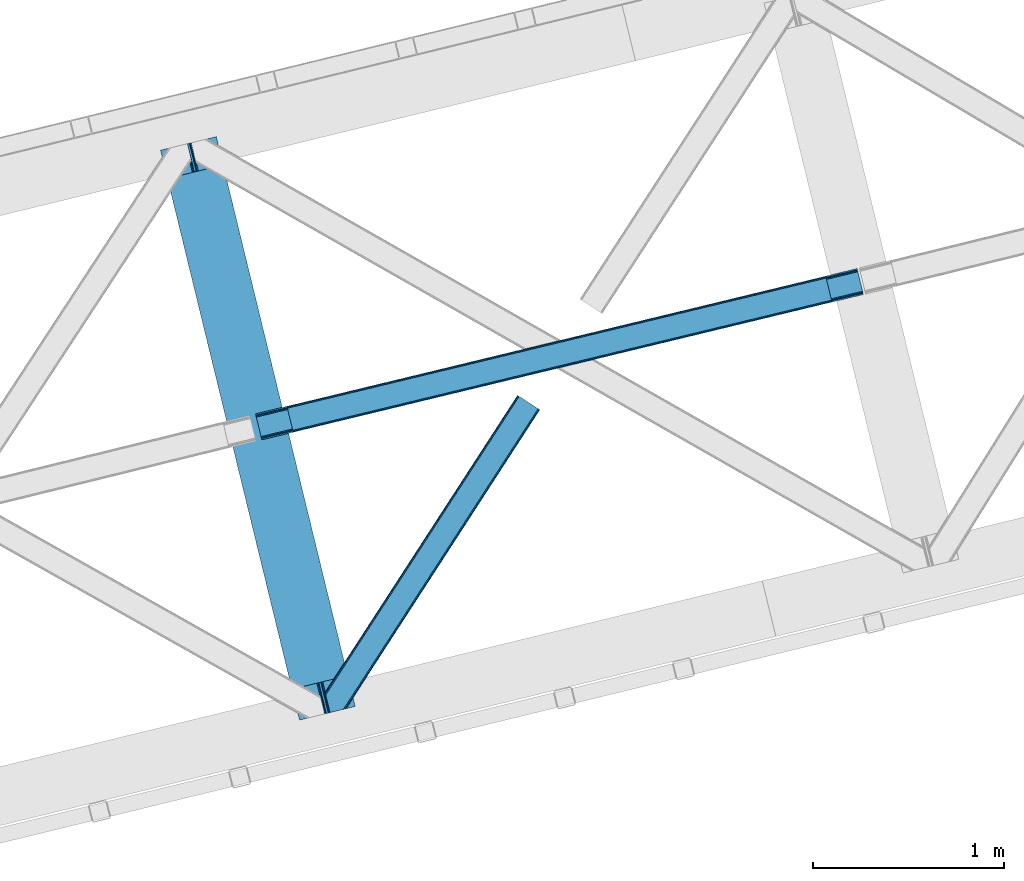
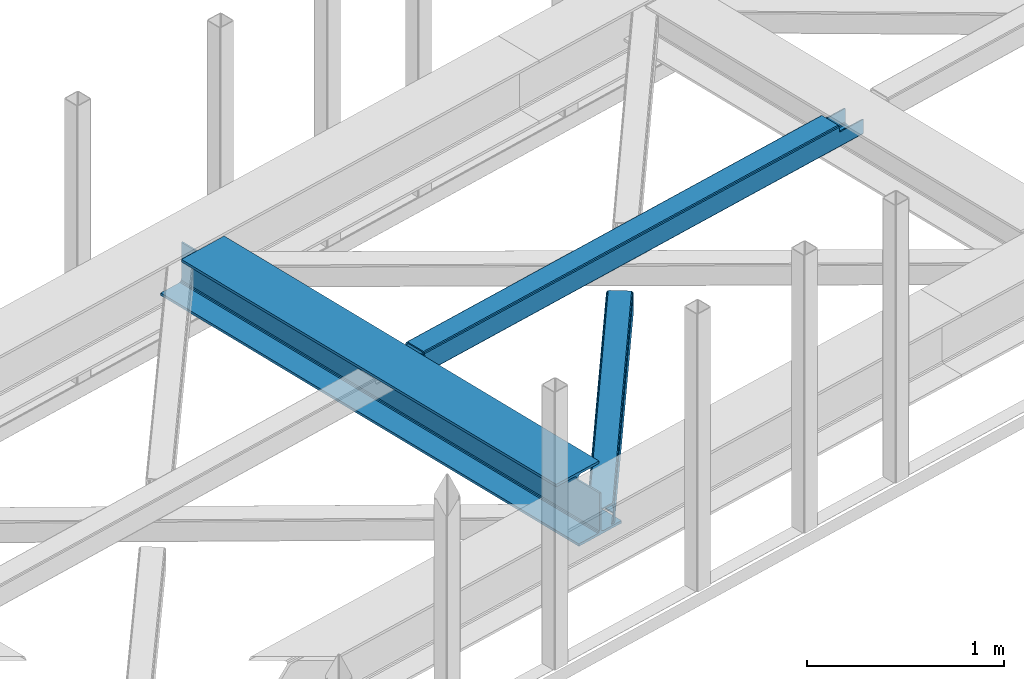
# One storey, part 36 of 67: 2 beams, 1 member.
"""IFC4 building model written with IfcOpenShell, lengths in millimetres."""

from ifc_helpers import new_model, entity, si_unit, converted_unit, derived_unit, direction, frame, origin, place, context, subcontext, project, spatial, triangles, polygons, material, type_object, element, save


model = new_model("IFC4")

# Units and contexts
model_context = context("Model", 3, precision=0.01, world=origin(), true_north=direction((6.12303176911189e-17, 1.0)))
plan_context = context("Plan", 3, precision=0.01, world=origin(), true_north=direction((6.12303176911189e-17, 1.0)))
body_context = subcontext(model_context, "Body", "Model", "MODEL_VIEW")
ifc_project = project(units=[si_unit("LENGTHUNIT", "METRE", prefix="MILLI"), si_unit("AREAUNIT", "SQUARE_METRE"), si_unit("VOLUMEUNIT", "CUBIC_METRE"), converted_unit("PLANEANGLEUNIT", "DEGREE", entity("IfcRatioMeasure", 0.0174532925199433), si_unit("PLANEANGLEUNIT", "RADIAN"), dimensions=[0, 0, 0, 0, 0, 0, 0]), si_unit("MASSUNIT", "GRAM", prefix="KILO"), derived_unit("MASSDENSITYUNIT", [(si_unit("MASSUNIT", "GRAM", prefix="KILO"), 1), (si_unit("LENGTHUNIT", "METRE"), -3)]), derived_unit("MOMENTOFINERTIAUNIT", [(si_unit("LENGTHUNIT", "METRE"), 4)]), si_unit("TIMEUNIT", "SECOND"), si_unit("FREQUENCYUNIT", "HERTZ"), si_unit("THERMODYNAMICTEMPERATUREUNIT", "DEGREE_CELSIUS"), derived_unit("THERMALTRANSMITTANCEUNIT", [(si_unit("MASSUNIT", "GRAM", prefix="KILO"), 1), (si_unit("THERMODYNAMICTEMPERATUREUNIT", "KELVIN"), -1), (si_unit("TIMEUNIT", "SECOND"), -3)]), derived_unit("VOLUMETRICFLOWRATEUNIT", [(si_unit("LENGTHUNIT", "METRE"), 3), (si_unit("TIMEUNIT", "SECOND"), -1)]), derived_unit("MASSFLOWRATEUNIT", [(si_unit("MASSUNIT", "GRAM", prefix="KILO"), 1), (si_unit("TIMEUNIT", "SECOND"), -1)]), derived_unit("ROTATIONALFREQUENCYUNIT", [(si_unit("TIMEUNIT", "SECOND"), -1)]), si_unit("ELECTRICCURRENTUNIT", "AMPERE"), si_unit("ELECTRICVOLTAGEUNIT", "VOLT"), si_unit("POWERUNIT", "WATT"), si_unit("FORCEUNIT", "NEWTON", prefix="KILO"), si_unit("ILLUMINANCEUNIT", "LUX"), si_unit("LUMINOUSFLUXUNIT", "LUMEN"), si_unit("LUMINOUSINTENSITYUNIT", "CANDELA"), derived_unit("USERDEFINED", [(si_unit("MASSUNIT", "GRAM", prefix="KILO"), -1), (si_unit("LENGTHUNIT", "METRE"), -2), (si_unit("TIMEUNIT", "SECOND"), 3), (si_unit("LUMINOUSFLUXUNIT", "LUMEN"), 1)]), derived_unit("LINEARVELOCITYUNIT", [(si_unit("LENGTHUNIT", "METRE"), 1), (si_unit("TIMEUNIT", "SECOND"), -1)]), si_unit("PRESSUREUNIT", "PASCAL"), derived_unit("USERDEFINED", [(si_unit("LENGTHUNIT", "METRE"), -2), (si_unit("MASSUNIT", "GRAM", prefix="KILO"), 1), (si_unit("TIMEUNIT", "SECOND"), -2)]), derived_unit("LINEARFORCEUNIT", [(si_unit("MASSUNIT", "GRAM", prefix="KILO"), 1), (si_unit("LENGTHUNIT", "METRE"), 1), (si_unit("TIMEUNIT", "SECOND"), -2), (si_unit("LENGTHUNIT", "METRE"), -1)]), derived_unit("PLANARFORCEUNIT", [(si_unit("MASSUNIT", "GRAM", prefix="KILO"), 1), (si_unit("LENGTHUNIT", "METRE"), 1), (si_unit("TIMEUNIT", "SECOND"), -2), (si_unit("LENGTHUNIT", "METRE"), -2)])], contexts=[model_context, plan_context])

# Site, building, storey
site_placement = place(None, origin())
site = spatial("IfcSite", under=ifc_project, at=site_placement, CompositionType="ELEMENT")
building_placement = place(site_placement, origin())
building = spatial("IfcBuilding", under=site, at=building_placement, CompositionType="ELEMENT")
storey_placement = place(building_placement, frame((0.0, 0.0, 19800.0)))
storey = spatial("IfcBuildingStorey", under=building, at=storey_placement, CompositionType="ELEMENT", Elevation=19800.0)

# Beams
ifc_material = material(Name="Metal painted (White)")
beam_type = type_object("IfcBeamType", PredefinedType="BEAM")
beam_1_placement = place(storey_placement, frame((-33462.5738387728, 9638.07281239183, 3807.02022389142)))
element("IfcBeam", 1, at=beam_1_placement, inside=storey, type_object=beam_type, material=ifc_material, ObjectType="Steel Beam", PredefinedType="BEAM", context=body_context, shape_type="Tessellation", body=[
    polygons([(1018.16648378329, 71.0478278971032, 15.5000000000008), (1018.16648378329, 71.0478278971032, 0.0), (291.465617442446, 3052.25531830422, 0.0), (291.465617442446, 3052.25531830421, 15.5000000000008), (894.779372399325, 40.970914087328, 15.5000000000008), (168.078506058474, 3022.17840449444, 15.5000000000008), (888.087028625375, 39.3395844888254, 16.8701684147984), (161.386162284524, 3020.54707489594, 16.8701684147984), (882.413533524755, 37.956610033653, 20.7720779386434), (155.7126671839, 3019.16410044076, 20.7720779386434), (878.62262529618, 37.0325360459173, 26.6116982174294), (151.921758955325, 3018.24002645303, 26.6116982174294), (877.291435352783, 36.708044413504, 33.500000000001), (150.590569011937, 3017.91553482062, 33.500000000001), (140.875048430518, 3015.54727389071, 33.500000000001), (140.875048430514, 3015.54727389071, 259.000000000002), (150.590569011932, 3017.91553482062, 259.000000000002), (-4.33146851719357e-12, 2981.20749040711, 0.0), (4.33146851719357e-12, 2981.20749040711, 15.4999999999965), (123.387111383968, 3011.28440421689, 15.5000000000008), (130.079455157926, 3012.91573381539, 16.8701684147984), (135.752950258542, 3014.29870827056, 20.7720779386391), (139.543858487122, 3015.2227822583, 26.6116982174294), (877.291435352779, 36.7080444135062, 259.000000000002), (867.575914771365, 34.3397834836025, 259.000000000002), (867.575914771365, 34.3397834836003, 33.500000000001), (866.244724827968, 34.0152918511859, 26.6116982174294), (862.453816599389, 33.0912178634513, 20.7720779386391), (856.780321498773, 31.7082434082789, 16.8701684147984), (850.087977724815, 30.0769138097752, 15.5000000000008), (726.700866340851, 2.16573425859679e-12, 15.4999999999965), (726.700866340851, 2.16573425859679e-12, 0.0), (838.124523615916, 197.385937999181, 259.069791973884), (186.469722099967, 2870.72539801218, 259.000000000002), (186.69311520182, 2869.80895360721, 259.617303331124), (186.705504045446, 2869.75812937344, 266.500003008253), (837.979344808143, 197.981416001706, 266.500002998871), (837.979694928895, 197.979979696973, 260.000004007589), (828.499586345872, 194.645865944432, 259.006343171919), (828.276216326111, 195.562317481914, 259.617303331124), (828.263827482481, 195.613141715685, 266.500003008253), (176.989986719788, 2867.38985508742, 266.500002998871), (176.989636599032, 2867.39129139215, 260.000004007589), (176.844830940692, 2867.98534020594, 259.07612046749), (176.754201518548, 2868.35713708228, 259.000000000002), (839.31083267807, 198.304685446393, 273.388305639783), (843.101109266766, 199.231350618306, 279.227924098781), (848.774180214305, 200.616065081981, 283.129832400619), (855.466371895425, 202.248018612794, 284.500000377228), (978.853400583278, 232.325271667905, 284.500000138971), (978.851730776613, 232.332121736637, 299.999995328161), (687.386308679347, 161.283492472594, 299.999995890962), (687.387978486003, 161.276642403863, 284.500000701776), (810.775007173847, 191.353895458974, 284.500000463519), (817.467494069986, 192.984637925555, 283.129832461069), (823.141405718746, 194.365903570076, 279.227924137322), (826.932940505738, 195.287407219375, 273.388305663684), (175.658498849857, 2867.06658564273, 273.388305639783), (171.868222261161, 2866.13992047082, 279.227924098781), (166.195151313627, 2864.75520600715, 283.129832400619), (159.502959632502, 2863.12325247633, 284.500000377228), (36.1159309446533, 2833.04599942122, 284.500000138971), (36.1176007513094, 2833.03914935249, 299.999995328161), (327.58302284858, 2904.08777861653, 299.999995890962), (327.581353041928, 2904.09462868526, 284.500000701776), (204.19432435408, 2874.01737563015, 284.500000463519), (197.501837457945, 2872.38663316357, 283.129832461069), (191.827925809185, 2871.00536751905, 279.227924137322), (188.036391022189, 2870.08386386975, 273.388305663684)], [[[1, 2, 3, 4]], [[5, 1, 4, 6]], [[7, 5, 6, 8]], [[9, 7, 8, 10]], [[11, 9, 10, 12]], [[13, 11, 12, 14]], [[15, 16, 17, 14, 12, 10, 8, 6, 4, 3, 18, 19, 20, 21, 22, 23]], [[13, 24, 25, 26, 27, 28, 29, 30, 31, 32, 2, 1, 5, 7, 9, 11]], [[2, 32, 18, 3]], [[32, 31, 19, 18]], [[31, 30, 20, 19]], [[27, 26, 15, 23]], [[28, 27, 23, 22]], [[29, 28, 22, 21]], [[30, 29, 21, 20]], [[33, 24, 13, 14, 17, 34, 35, 36, 37, 38]], [[25, 39, 40, 41, 42, 43, 44, 16, 15, 26]], [[39, 25, 24, 33]], [[45, 34, 17, 16]], [[41, 40, 38, 37, 46, 47, 48, 49, 50, 51, 52, 53, 54, 55, 56, 57]], [[42, 58, 59, 60, 61, 62, 63, 64, 65, 66, 67, 68, 69, 36, 35, 43]], [[46, 37, 36, 69]], [[47, 46, 69, 68]], [[48, 47, 68, 67]], [[49, 48, 67, 66]], [[50, 49, 66, 65]], [[51, 50, 65, 64]], [[52, 51, 64, 63]], [[53, 52, 63, 62]], [[54, 53, 62, 61]], [[55, 54, 61, 60]], [[56, 55, 60, 59]], [[57, 56, 59, 58]], [[41, 57, 58, 42]]], closed=False),
])
beam_2_placement = place(storey_placement, frame((-32965.8347717069, 11104.1585066842, 3967.02199347534)))
element("IfcBeam", 2, at=beam_2_placement, inside=storey, type_object=beam_type, material=ifc_material, ObjectType="Steel Beam", PredefinedType="BEAM", context=body_context, shape_type="Tessellation", body=[
    polygons([(195.773362086805, 46.4834740443067, 115.55102592408), (195.457883430396, 47.7776892807251, 122.247985460716), (3014.38527381378, 728.721626181414, 123.12224722229), (3014.70075247017, 727.427410945045, 116.425287685654), (194.559476226856, 51.4633024520939, 127.925391947854), (3013.48686661024, 732.407239352741, 128.799653709428), (193.214914828827, 56.9792123632816, 131.718911713636), (3012.14230521221, 737.923149263937, 132.59317347521), (191.628896520703, 63.485671732071, 133.051015762066), (3010.55628690406, 744.429608632842, 133.925277523644), (170.077675576957, 151.897099708507, 133.050958784443), (2989.00506596032, 832.84103660928, 133.925220546017), (168.491657268782, 158.403559077509, 131.718846349701), (2987.41904765216, 839.347495978191, 132.593108111284), (167.147095870749, 163.919468988697, 127.925319474355), (2986.07448625413, 844.863405889383, 128.799581235929), (166.248688667217, 167.605082160037, 122.247908236757), (2985.17607905059, 848.549019060736, 123.122169998335), (165.933210010851, 168.8992973963, 115.550947031982), (2984.86060039422, 849.843234297047, 116.425208793556), (2983.20281416778, 856.644113372169, 101.478006524657), (2983.20281416778, 856.644113372165, 123.425204728752), (2983.51829282418, 855.349898135762, 130.122165933532), (2984.41670002772, 851.664284964408, 135.79957717113), (2985.76126142575, 846.148375053212, 139.59310404648), (2987.34727973389, 839.641915684392, 140.925216481214), (3012.21407313051, 737.628729557732, 140.925282224628), (3013.8000914387, 731.122270188704, 139.59317817619), (3015.14465283673, 725.606360277508, 135.799658410417), (3016.04306004026, 721.920747106161, 130.122251923274), (3016.35853869166, 720.626531890475, 123.425292386639), (3016.35853869662, 720.626531869957, 101.478006524657), (3014.70075247017, 727.427410945067, 101.478006524657), (2984.86060039423, 849.84323429706, 101.478006524657), (165.933210010851, 168.899297396285, 100.498230416086), (195.773362086805, 46.4834740442915, 100.498230416086), (197.431148312824, 39.6825949709209, 100.498230416086), (197.43114831324, 39.6825949691927, 122.551030625065), (197.115669656861, 40.9768102055115, 129.247990161705), (196.217262453329, 44.6624233768565, 134.925396648843), (194.872701055296, 50.1783332880529, 138.718916414629), (193.286682747138, 56.6847926569592, 140.05102046305), (168.419889350514, 158.697978783619, 140.05095471964), (166.833871042356, 165.204438152528, 138.718842284902), (165.489309644327, 170.72034806372, 134.925315409556), (164.590902440796, 174.40596123506, 129.247904171949), (164.275423784408, 175.700176471401, 122.550942967179), (164.275423784408, 175.700176471396, 100.498230416086), (3178.97617625457, 767.110005888593, 100.478006524658), (3178.97617625457, 767.110005888593, 25.476231908301), (31.4979383023929, 6.8008791007736, 24.5000734310727), (31.4979383023973, 6.80087910076277, 99.4982304160815), (194.801318159086, 46.2486657901886, 99.4982304160858), (1.657786226439, 129.21670245276, 24.4999945389742), (3149.13602417862, 889.525829240584, 25.4761530162069), (3149.13602417862, 889.525829240586, 100.478006524658), (2985.83264432192, 850.078042551158, 100.478006524658), (1.65778622644333, 129.216702452756, 99.4982304160815), (3180.63396247261, 760.309126848315, 18.4762359731086), (3180.63396244516, 760.309126959369, 100.478006524658), (3017.33058261229, 720.861340173872, 100.478006524658), (33.1557245287323, 2.60754404735053e-08, 99.4982304160815), (33.1557245329728, 8.55031885294011e-09, 17.5000774958759), (3147.47823795218, 896.326708315696, 100.478006524658), (3147.47823795218, 896.326708315694, 18.4761483152224), (0.0, 136.017581527866, 17.4999898379897), (0.0, 136.017581527868, 99.4982304160815), (163.303379856698, 175.465368217291, 99.4982304160858), (3015.67279639788, 727.662219199167, 100.478006524658), (2984.17485809549, 856.878921626272, 100.478006524658), (3149.451502835, 888.231614004263, 18.7791934795625), (3150.34991003854, 884.546000832907, 13.1017869924287), (3151.69447143658, 879.030090921715, 9.30826722664713), (3153.28048974473, 872.523631552807, 7.97616317822152), (3174.83171068847, 784.112203576368, 7.97622015583976), (3176.41772899663, 777.605744207462, 9.30833259058183), (3177.76229039466, 772.08983429627, 13.1018594659232), (3178.66069759819, 768.404221124921, 18.7792707035258), (3180.31848382461, 761.603342049926, 11.779274768316), (3179.42007662107, 765.288955221284, 6.10186353071347), (3178.07551522304, 770.804865132474, 2.30833665536775), (3176.48949691491, 777.311324501259, 0.976224220647339), (3151.62270351829, 879.324510627918, 0.976158477228353), (3150.03668521011, 885.830969996914, 2.30826252564963), (3148.69212381207, 891.346879908106, 6.10178229143121), (3147.79371660855, 895.032493079451, 11.7791887785693), (196.459104385525, 39.4477867150768, 99.4982304160858), (164.961166083132, 168.664489142182, 99.4982304160858), (27.3534727362954, 23.803076788538, 7.0000616786114), (28.939491044419, 17.2966174197507, 8.33217411333182), (30.2840524424519, 11.7807075085608, 12.1257009886819), (31.1824596459836, 8.0950943372072, 17.8031122262801), (1.97326488280931, 127.922487216496, 17.8030350023211), (2.87167208633673, 124.236874045166, 12.125628515183), (4.21623348436958, 118.720964133976, 8.33210874940145), (5.80225179254949, 112.214504764981, 7.00000470098017), (0.315478656383311, 134.723366291536, 10.8030303013496), (1.21388585991939, 131.037753120189, 5.12562381421585), (2.55844725794791, 125.521843208997, 1.33210404842994), (4.14446556610183, 119.015383840088, 4.33146851719357e-12), (29.0112589627301, 17.0021977134283, 6.5743414654662e-05), (30.597277270884, 10.4957383445198, 1.33217817815239), (31.9418386689169, 4.97982843332773, 5.12570505349811), (32.8402458724486, 1.29421526199143, 10.8031162910963)], [[[1, 2, 3, 4]], [[2, 5, 6, 3]], [[5, 7, 8, 6]], [[7, 9, 10, 8]], [[11, 12, 10, 9]], [[11, 13, 14, 12]], [[13, 15, 16, 14]], [[15, 17, 18, 16]], [[17, 19, 20, 18]], [[21, 22, 23, 24, 25, 26, 27, 28, 29, 30, 31, 32, 33, 4, 3, 6, 8, 10, 12, 14, 16, 18, 20, 34]], [[35, 19, 17, 15, 13, 11, 9, 7, 5, 2, 1, 36, 37, 38, 39, 40, 41, 42, 43, 44, 45, 46, 47, 48]], [[42, 41, 28, 27]], [[41, 40, 29, 28]], [[40, 39, 30, 29]], [[39, 38, 31, 30]], [[27, 26, 43, 42]], [[47, 46, 23, 22]], [[46, 45, 24, 23]], [[45, 44, 25, 24]], [[44, 43, 26, 25]], [[33, 49, 50, 51, 52, 53, 1, 4]], [[54, 55, 56, 57, 20, 19, 35, 58]], [[59, 60, 61, 31, 38, 37, 62, 63]], [[64, 65, 66, 67, 68, 47, 22, 21]], [[61, 60, 49, 69]], [[64, 70, 57, 56]], [[65, 64, 56, 55, 71, 72, 73, 74, 75, 76, 77, 78, 50, 49, 60, 59, 79, 80, 81, 82, 83, 84, 85, 86]], [[87, 53, 52, 62]], [[67, 58, 88, 68]], [[89, 90, 76, 75]], [[90, 91, 77, 76]], [[91, 92, 78, 77]], [[92, 51, 50, 78]], [[54, 93, 71, 55]], [[93, 94, 72, 71]], [[94, 95, 73, 72]], [[95, 96, 74, 73]], [[89, 75, 74, 96]], [[66, 97, 98, 99, 100, 101, 102, 103, 104, 63, 62, 52, 51, 92, 91, 90, 89, 96, 95, 94, 93, 54, 58, 67]], [[63, 104, 79, 59]], [[104, 103, 80, 79]], [[103, 102, 81, 80]], [[102, 101, 82, 81]], [[100, 99, 84, 83]], [[99, 98, 85, 84]], [[98, 97, 86, 85]], [[97, 66, 65, 86]], [[83, 82, 101, 100]]], closed=False),
])

# Member
member_type = type_object("IfcMemberType", PredefinedType="BRACE")
member_placement = place(storey_placement, frame((-32601.7216552734, 9677.14885253906, 3823.05807495117)))
element("IfcMember", 3, at=member_placement, inside=storey, type_object=member_type, ObjectType="Steel Horizontal Brace", PredefinedType="BRACE", context=body_context, shape_type="Tessellation", body=[
    triangles([(1021.07255859375, 1650.67133789062, 0.386022949220205), (1109.18811035156, 1593.56668395996, 0.386022949220205), (114.153497314452, 251.255593872071, 0.0209289550803078), (148.353735351564, 110.958343505859, 0.0), (1007.50594482422, 1659.46266174316, 11.1900146484368), (0.523223876953125, 105.142419433594, 10.8528259277336), (0.0, 107.29112548828, 17.4803283691399), (108.346874999999, 270.855560302734, 9.46221313476781), (0.634844970703853, 104.692446899413, 9.46221313476781), (1010.68947143555, 1657.39999694824, 5.51361694336083), (110.123510742189, 267.789468383789, 5.14852294922093), (109.277050781249, 271.259024047851, 8.46227416992406), (108.646856689455, 271.243908691406, 9.38547363281396), (1015.454296875, 1654.31297607422, 1.71849975586156), (111.972235107423, 260.203884887695, 1.3557312011726), (1006.38740844727, 1660.18587341309, 17.8872802734368), (1006.37345581055, 1660.16610717773, 122.887847900391), (0.0, 107.29112548828, 122.480895996094), (1021.05860595703, 1650.64575805664, 140.386779785156), (1015.43801879883, 1654.28855895996, 139.054302978515), (3.51838989257885, 92.8559600830067, 138.647351074218), (5.69965209961083, 83.9088317871083, 139.977502441408), (1010.67319335938, 1657.37674255371, 135.26151123047), (1.66966552734448, 100.442706298827, 134.854559326173), (1007.4919921875, 1659.44057006836, 129.58278808594), (0.434857177733647, 105.511001586914, 129.178161621094), (112.781488037108, 252.660159301757, 9.46221313476781), (5.05317993164135, 86.5644836425781, 9.46221313476781), (1021.32603149414, 1650.50506896973, 8.71807250976781), (113.111700439455, 252.928747558593, 9.38547363281396), (113.818634033203, 251.768353271484, 8.76923217773583), (1016.56353149414, 1653.59208984375, 12.5131896972671), (3.95092163085792, 91.089788818359, 12.1039123535156), (1026.9489440918, 1646.86343078613, 7.3879211425774), (114.255816650391, 250.833526611328, 8.40646362304688), (116.434753417969, 241.902676391601, 7.02050170898656), (1013.38000488281, 1655.65475463867, 18.189587402343), (2.71378784179615, 96.1580841064442, 17.7826354980461), (1012.25914306641, 1656.37680358887, 24.886853027343), (2.28125610351708, 97.9382080078121, 24.4799011230461), (1103.31172485352, 1597.372265625, 7.3879211425774), (146.072479248047, 120.311260986327, 7.00189819336083), (150.534997558592, 102.010052490234, 1.33015136718677), (148.353735351564, 110.953692626952, 8.46227416992406), (152.383721923827, 94.4244689941406, 5.1229431152351), (153.234832763672, 90.9316589355458, 8.46227416992406), (1012.24984130859, 1656.36052551269, 115.885949707033), (2.28125610351708, 97.9382080078121, 115.478997802737), (1013.36837768555, 1655.63498840332, 122.583215332033), (2.71378784179615, 96.1580841064442, 122.176263427737), (1016.54957885742, 1653.57116088867, 128.261938476564), (3.95092163085792, 91.089788818359, 127.852661132813), (1021.31207885742, 1650.48297729492, 132.054730224609), (5.79964599609229, 83.5030426025387, 131.645452880861), (1026.93266601563, 1646.8401763916, 133.38720703125), (7.98090820312427, 74.554751586913, 132.975604248048), (26.1542175292961, 0.0, 139.963549804688), (26.1542175292961, 0.0, 132.963977050782), (1109.17183227539, 1593.54110412598, 140.386779785156), (85.8808044433608, 14.5589950561516, 139.975177001954), (1103.30009765625, 1597.3501739502, 133.38720703125), (75.9744323730483, 12.1440261840817, 132.973278808593), (1123.85930786133, 1584.02656860351, 122.887847900391), (1122.74077148438, 1584.75094299316, 129.58278808594), (110.646734619142, 20.5958358764638, 122.478570556643), (108.760803222656, 20.1359802246097, 129.175836181643), (1119.55724487305, 1586.81244506836, 135.26151123047), (103.391363525392, 18.8279205322269, 134.852233886719), (1114.79241943359, 1589.89946594238, 139.054302978515), (95.3569702148452, 16.8693191528309, 138.645025634767), (1123.87093505859, 1584.04633483887, 17.8872802734368), (110.646734619142, 20.5958358764638, 17.478002929689), (1122.75472412109, 1584.77187194824, 11.1900146484368), (1113.69713745117, 1590.64244384766, 12.5131896972671), (1116.8806640625, 1588.57861633301, 18.189587402343), (1117.996875, 1587.85191650391, 24.886853027343), (1119.57119750977, 1586.83686218262, 5.51361694336083), (1114.80869750976, 1589.92504577637, 1.71849975586156), (1108.93231201172, 1593.73062744141, 8.71807250976781), (1113.68318481445, 1590.62035217285, 128.261938476564), (1117.98524780274, 1587.83563842773, 115.885949707033), (1116.86903686524, 1588.55885009766, 122.583215332033), (1108.918359375, 1593.70737304687, 132.054730224609), (85.4505981445327, 14.454350280761, 131.643127441406), (93.4849914550796, 16.4129516601552, 127.850335693362), (98.8521057128892, 17.721011352538, 122.173937988282), (100.74036254883, 18.1808670043938, 115.476672363282), (100.74036254883, 18.1808670043938, 24.4775756835952), (93.4849914550796, 16.4129516601552, 12.1015869140647), (107.895739746094, 19.9255279541012, 9.46221313476781), (98.8521057128892, 17.721011352538, 17.7803100585952), (88.6992370605476, 15.2461624145508, 9.46221313476781), (108.372454833985, 20.0412185668938, 10.8481750488281), (152.669750976562, 89.0306121826161, 9.46221313476781), (153.097631835939, 90.4723846435536, 8.7041198730476), (148.239788818359, 107.195782470702, 9.46221313476781), (148.563024902345, 109.771206665038, 8.84597167968968), (148.458380126955, 108.917770385742, 9.05061035156177), (148.349084472655, 108.050381469726, 9.25757446289208)], [[1, 2, 3], [4, 3, 2], [5, 6, 7], [8, 6, 5], [8, 9, 6], [10, 11, 12], [12, 5, 10], [12, 13, 5], [10, 14, 11], [15, 11, 14], [14, 1, 15], [3, 15, 1], [7, 16, 5], [17, 16, 18], [7, 18, 16], [19, 20, 21], [21, 22, 19], [20, 23, 24], [24, 21, 20], [23, 25, 26], [26, 24, 23], [25, 17, 18], [18, 26, 25], [8, 27, 9], [28, 9, 27], [29, 30, 31], [32, 33, 27], [27, 29, 32], [33, 28, 27], [34, 29, 35], [35, 36, 34], [32, 37, 38], [38, 33, 32], [37, 39, 40], [40, 38, 37], [41, 34, 36], [36, 42, 41], [36, 3, 42], [15, 35, 11], [35, 15, 3], [11, 35, 12], [3, 36, 35], [42, 3, 4], [43, 44, 4], [44, 43, 45], [4, 44, 42], [45, 46, 44], [39, 47, 48], [48, 40, 39], [47, 49, 48], [50, 48, 49], [49, 51, 50], [52, 50, 51], [51, 53, 52], [54, 52, 53], [53, 55, 54], [56, 54, 55], [52, 24, 50], [54, 56, 22], [56, 57, 22], [56, 58, 57], [21, 54, 22], [52, 21, 24], [33, 9, 28], [52, 54, 21], [7, 40, 48], [48, 50, 18], [18, 7, 48], [24, 26, 50], [50, 26, 18], [7, 38, 40], [38, 9, 33], [9, 38, 6], [7, 6, 38], [59, 22, 60], [59, 19, 22], [22, 57, 60], [61, 56, 55], [56, 61, 62], [58, 56, 62], [63, 64, 65], [66, 65, 64], [64, 67, 66], [68, 66, 67], [67, 69, 68], [70, 68, 69], [69, 59, 70], [60, 70, 59], [71, 63, 65], [65, 72, 71], [73, 74, 75], [76, 63, 71], [73, 75, 71], [73, 77, 74], [75, 76, 71], [74, 77, 78], [41, 2, 1], [2, 79, 78], [79, 2, 41], [79, 74, 78], [64, 80, 67], [81, 63, 76], [63, 82, 64], [82, 63, 81], [64, 82, 80], [59, 61, 19], [69, 67, 80], [80, 83, 69], [83, 61, 59], [59, 69, 83], [32, 14, 10], [1, 34, 41], [1, 29, 34], [29, 1, 14], [32, 29, 14], [39, 16, 17], [5, 37, 32], [10, 5, 32], [37, 5, 16], [39, 37, 16], [20, 51, 23], [19, 61, 55], [55, 53, 19], [53, 51, 20], [20, 19, 53], [25, 23, 51], [17, 47, 39], [49, 17, 25], [17, 49, 47], [49, 25, 51], [61, 83, 84], [84, 62, 61], [83, 80, 85], [85, 84, 83], [80, 82, 86], [86, 85, 80], [82, 81, 87], [87, 86, 82], [81, 76, 87], [88, 87, 76], [86, 65, 66], [84, 70, 60], [62, 57, 58], [60, 62, 84], [62, 60, 57], [85, 70, 84], [85, 86, 68], [68, 70, 85], [66, 68, 86], [72, 65, 87], [89, 90, 91], [86, 87, 65], [89, 92, 90], [88, 91, 72], [88, 72, 87], [93, 72, 91], [91, 90, 93], [73, 71, 72], [77, 94, 95], [46, 45, 77], [73, 93, 94], [94, 77, 73], [93, 90, 94], [2, 78, 4], [43, 4, 78], [78, 77, 43], [45, 43, 77], [72, 93, 73], [79, 41, 42], [89, 74, 96], [74, 79, 44], [44, 97, 74], [74, 98, 99], [98, 74, 97], [99, 96, 74], [96, 92, 89], [42, 44, 79], [76, 75, 88], [91, 88, 75], [75, 74, 91], [89, 91, 74], [96, 99, 94], [99, 98, 95], [98, 97, 95], [97, 44, 46], [96, 94, 90], [90, 92, 96]]),
])

save(model, "model.ifc")
